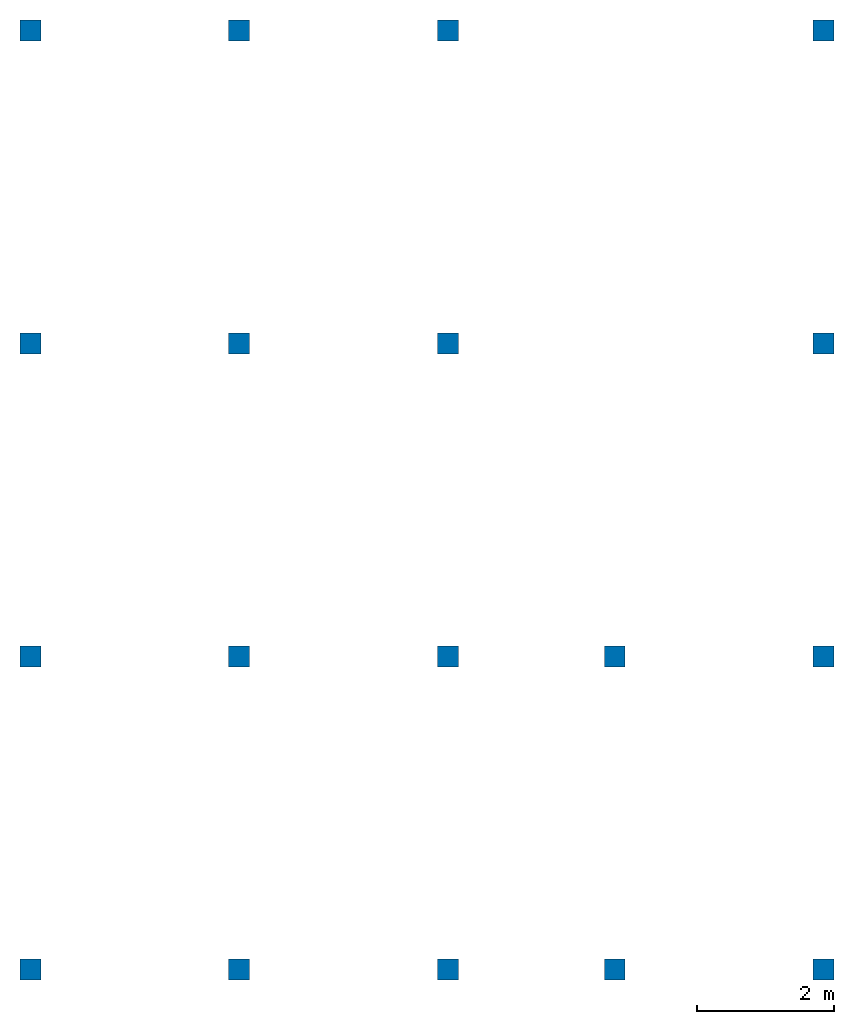
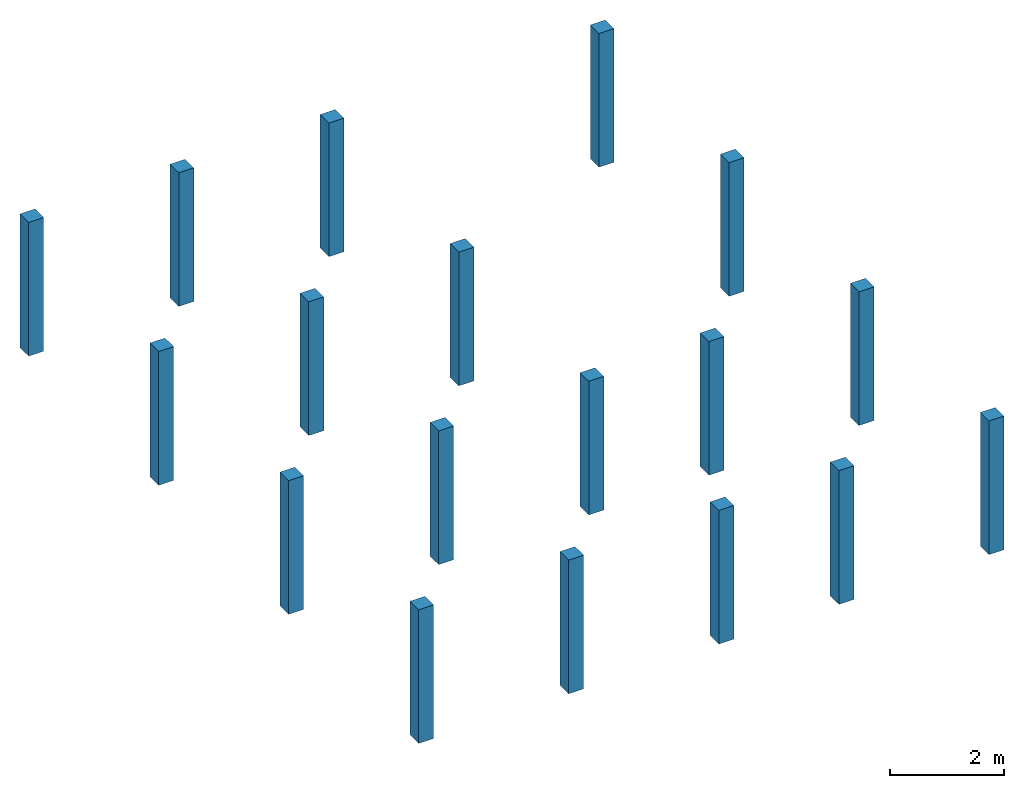
# One storey: 18 columns.
"""IFC2X3 building model written with IfcOpenShell, lengths in feet."""

from ifc_helpers import new_model, entity, si_unit, converted_unit, derived_unit, direction, frame, origin, origin_2d_with_axis, place, context, subcontext, project, spatial, rectangle, extrude, source, transform, mapped, material, type_object, type_shapes, element, save


model = new_model("IFC2X3")

# Units and contexts
model_context = context("Model", 3, precision=0.0001, world=origin(), true_north=direction((6.123031769111886e-17, 1.0)))
body_context = subcontext(model_context, "Body", "Model", "MODEL_VIEW")
ifc_project = project(units=[converted_unit("LENGTHUNIT", "FOOT", entity("IfcLengthMeasure", 0.3048), si_unit("LENGTHUNIT", "METRE"), dimensions=[1, 0, 0, 0, 0, 0, 0]), converted_unit("AREAUNIT", "SQUARE FOOT", entity("IfcAreaMeasure", 0.09290304), si_unit("AREAUNIT", "SQUARE_METRE"), dimensions=[2, 0, 0, 0, 0, 0, 0]), converted_unit("VOLUMEUNIT", "CUBIC FOOT", entity("IfcVolumeMeasure", 0.028316846592000004), si_unit("VOLUMEUNIT", "CUBIC_METRE"), dimensions=[3, 0, 0, 0, 0, 0, 0]), converted_unit("PLANEANGLEUNIT", "DEGREE", entity("IfcPlaneAngleMeasure", 0.017453292519943278), si_unit("PLANEANGLEUNIT", "RADIAN"), dimensions=[0, 0, 0, 0, 0, 0, 0]), si_unit("MASSUNIT", "GRAM", prefix="KILO"), derived_unit("MASSDENSITYUNIT", [(si_unit("MASSUNIT", "GRAM", prefix="KILO"), 1), (si_unit("LENGTHUNIT", "METRE"), -3)]), derived_unit("IONCONCENTRATIONUNIT", [(si_unit("MASSUNIT", "GRAM", prefix="KILO"), 1), (si_unit("LENGTHUNIT", "METRE"), -3)]), derived_unit("MOMENTOFINERTIAUNIT", [(si_unit("LENGTHUNIT", "METRE"), 4)]), si_unit("TIMEUNIT", "SECOND"), si_unit("FREQUENCYUNIT", "HERTZ"), si_unit("THERMODYNAMICTEMPERATUREUNIT", "DEGREE_CELSIUS"), derived_unit("THERMALTRANSMITTANCEUNIT", [(si_unit("MASSUNIT", "GRAM", prefix="KILO"), 1), (si_unit("THERMODYNAMICTEMPERATUREUNIT", "KELVIN"), -1), (si_unit("TIMEUNIT", "SECOND"), -3)]), derived_unit("THERMALCONDUCTANCEUNIT", [(si_unit("MASSUNIT", "GRAM", prefix="KILO"), 1), (si_unit("THERMODYNAMICTEMPERATUREUNIT", "KELVIN"), -1), (si_unit("TIMEUNIT", "SECOND"), -3), (si_unit("LENGTHUNIT", "METRE"), 1)]), derived_unit("VOLUMETRICFLOWRATEUNIT", [(si_unit("LENGTHUNIT", "METRE"), 3), (si_unit("TIMEUNIT", "SECOND"), -1)]), derived_unit("MASSFLOWRATEUNIT", [(si_unit("MASSUNIT", "GRAM", prefix="KILO"), 1), (si_unit("TIMEUNIT", "SECOND"), -1)]), derived_unit("ROTATIONALFREQUENCYUNIT", [(si_unit("TIMEUNIT", "SECOND"), -1)]), si_unit("ELECTRICCURRENTUNIT", "AMPERE"), si_unit("ELECTRICVOLTAGEUNIT", "VOLT"), si_unit("POWERUNIT", "WATT"), converted_unit("FORCEUNIT", "KIP", entity("IfcForceMeasure", 2.088543423315013e-05), si_unit("FORCEUNIT", "NEWTON"), dimensions=[1, 1, -2, 0, 0, 0, 0]), si_unit("ILLUMINANCEUNIT", "LUX"), si_unit("LUMINOUSFLUXUNIT", "LUMEN"), si_unit("LUMINOUSINTENSITYUNIT", "CANDELA"), si_unit("ENERGYUNIT", "JOULE"), derived_unit("USERDEFINED", [(si_unit("MASSUNIT", "GRAM", prefix="KILO"), -1), (si_unit("LENGTHUNIT", "METRE"), -2), (si_unit("TIMEUNIT", "SECOND"), 3), (si_unit("LUMINOUSFLUXUNIT", "LUMEN"), 1)]), derived_unit("USERDEFINED", [(si_unit("MASSUNIT", "GRAM", prefix="KILO"), 1), (si_unit("TIMEUNIT", "SECOND"), -3), (si_unit("LENGTHUNIT", "METRE"), 3), (si_unit("ELECTRICCURRENTUNIT", "AMPERE"), -2)]), derived_unit("SOUNDPOWERUNIT", [(si_unit("MASSUNIT", "GRAM", prefix="KILO"), 1), (si_unit("TIMEUNIT", "SECOND"), -3), (si_unit("LENGTHUNIT", "METRE"), 2)]), derived_unit("SOUNDPRESSUREUNIT", [(si_unit("MASSUNIT", "GRAM", prefix="KILO"), 1), (si_unit("LENGTHUNIT", "METRE"), -1), (si_unit("TIMEUNIT", "SECOND"), -2)]), derived_unit("LINEARVELOCITYUNIT", [(si_unit("LENGTHUNIT", "METRE"), 1), (si_unit("TIMEUNIT", "SECOND"), -1)]), si_unit("PRESSUREUNIT", "PASCAL"), derived_unit("USERDEFINED", [(si_unit("MASSUNIT", "GRAM", prefix="KILO"), 1), (si_unit("LENGTHUNIT", "METRE"), -2), (si_unit("TIMEUNIT", "SECOND"), -2)]), derived_unit("LINEARFORCEUNIT", [(si_unit("MASSUNIT", "GRAM", prefix="KILO"), 1), (si_unit("TIMEUNIT", "SECOND"), -2)]), derived_unit("PLANARFORCEUNIT", [(si_unit("MASSUNIT", "GRAM", prefix="KILO"), 1), (si_unit("LENGTHUNIT", "METRE"), -1), (si_unit("TIMEUNIT", "SECOND"), -2)]), derived_unit("SPECIFICHEATCAPACITYUNIT", [(si_unit("THERMODYNAMICTEMPERATUREUNIT", "KELVIN"), -1), (si_unit("LENGTHUNIT", "METRE"), 2), (si_unit("TIMEUNIT", "SECOND"), -2)]), derived_unit("HEATFLUXDENSITYUNIT", [(si_unit("MASSUNIT", "GRAM", prefix="KILO"), 1), (si_unit("TIMEUNIT", "SECOND"), -3)]), derived_unit("HEATINGVALUEUNIT", [(si_unit("LENGTHUNIT", "METRE"), 2), (si_unit("TIMEUNIT", "SECOND"), -2)]), derived_unit("VAPORPERMEABILITYUNIT", [(si_unit("LENGTHUNIT", "METRE"), -1), (si_unit("TIMEUNIT", "SECOND"), 1)]), derived_unit("DYNAMICVISCOSITYUNIT", [(si_unit("MASSUNIT", "GRAM", prefix="KILO"), 1), (si_unit("TIMEUNIT", "SECOND"), -1), (si_unit("LENGTHUNIT", "METRE"), -1)]), derived_unit("THERMALEXPANSIONCOEFFICIENTUNIT", [(si_unit("THERMODYNAMICTEMPERATUREUNIT", "KELVIN"), -1)]), derived_unit("MODULUSOFELASTICITYUNIT", [(si_unit("MASSUNIT", "GRAM", prefix="KILO"), 1), (si_unit("LENGTHUNIT", "METRE"), -1), (si_unit("TIMEUNIT", "SECOND"), -2)]), derived_unit("ISOTHERMALMOISTURECAPACITYUNIT", [(si_unit("LENGTHUNIT", "METRE"), 3), (si_unit("MASSUNIT", "GRAM", prefix="KILO"), -1)]), derived_unit("MOISTUREDIFFUSIVITYUNIT", [(si_unit("TIMEUNIT", "SECOND"), -1), (si_unit("LENGTHUNIT", "METRE"), 2)]), derived_unit("MASSPERLENGTHUNIT", [(si_unit("MASSUNIT", "GRAM", prefix="KILO"), 1), (si_unit("LENGTHUNIT", "METRE"), -1)]), derived_unit("THERMALRESISTANCEUNIT", [(si_unit("MASSUNIT", "GRAM", prefix="KILO"), -1), (si_unit("TIMEUNIT", "SECOND"), 3), (si_unit("THERMODYNAMICTEMPERATUREUNIT", "KELVIN"), 1)]), derived_unit("ACCELERATIONUNIT", [(si_unit("LENGTHUNIT", "METRE"), 1), (si_unit("TIMEUNIT", "SECOND"), -2)]), derived_unit("ANGULARVELOCITYUNIT", [(si_unit("TIMEUNIT", "SECOND"), -1), (si_unit("PLANEANGLEUNIT", "RADIAN"), 1)]), derived_unit("LINEARSTIFFNESSUNIT", [(si_unit("MASSUNIT", "GRAM", prefix="KILO"), 1), (si_unit("TIMEUNIT", "SECOND"), -2)]), derived_unit("WARPINGCONSTANTUNIT", [(si_unit("LENGTHUNIT", "METRE"), 6)]), derived_unit("LINEARMOMENTUNIT", [(si_unit("MASSUNIT", "GRAM", prefix="KILO"), 1), (si_unit("LENGTHUNIT", "METRE"), 1), (si_unit("TIMEUNIT", "SECOND"), -2)]), derived_unit("TORQUEUNIT", [(si_unit("MASSUNIT", "GRAM", prefix="KILO"), 1), (si_unit("LENGTHUNIT", "METRE"), 2), (si_unit("TIMEUNIT", "SECOND"), -2)])], contexts=[model_context])

# Site, building, storey
site_placement = place(None, origin())
site = spatial("IfcSite", under=ifc_project, at=site_placement, CompositionType="ELEMENT")
building_placement = place(site_placement, origin())
building = spatial("IfcBuilding", under=site, at=building_placement, CompositionType="ELEMENT")
storey_placement = place(building_placement, origin())
storey = spatial("IfcBuildingStorey", under=building, at=storey_placement, Name="Ground Floor", CompositionType="ELEMENT", Elevation=0.0)

# Columns
ifc_material = material(Name="Concrete, Cast-in-Place gray")
column_type = type_object("IfcColumnType", PredefinedType="COLUMN", material=ifc_material)
shared_shape = source(origin(), body_context, "Body", "SweptSolid", [
    extrude(rectangle(XDim=0.9999999999999999, YDim=0.9999999999999999, at=origin_2d_with_axis()), frame((0.0, 0.0, 0.0), z_axis=(0.0, 0.0, 1.0), x_axis=(-1.0, 0.0, 0.0)), (0.0, 0.0, 1.0), 9.416666666670961),
])
type_shapes(column_type, [shared_shape])
for number, where in (
    (1, (9.874478019162162, -49.84124484724893, 0.0)),
    (2, (29.874478019162154, -49.841244847248994, 0.0)),
    (3, (37.87447801916216, -49.84124484724902, 0.0)),
    (4, (47.87447801916217, -49.84124484724906, 0.0)),
    (5, (19.874478019162158, -49.841244847248966, 0.0)),
    (6, (9.874478019162186, -34.84124484724893, 0.0)),
    (7, (29.87447801916219, -34.841244847248994, 0.0)),
    (8, (37.87447801916219, -34.84124484724902, 0.0)),
    (9, (47.87447801916219, -34.84124484724906, 0.0)),
    (10, (19.874478019162183, -34.841244847248966, 0.0)),
    (11, (9.874478019162211, -19.841244847248934, 0.0)),
    (12, (29.87447801916221, -19.841244847248998, 0.0)),
    (13, (47.87447801916221, -19.841244847249058, 0.0)),
    (14, (19.874478019162204, -19.841244847248966, 0.0)),
    (15, (9.874478019162234, -4.841244847248884, 0.0)),
    (16, (29.874478019162233, -4.841244847248948, 0.0)),
    (17, (47.87447801916224, -4.841244847249006, 0.0)),
    (18, (19.87447801916223, -4.841244847248915, 0.0)),
):
    element("IfcColumn", number, at=place(storey_placement, frame(where)), inside=storey, type_object=column_type, material=ifc_material, context=body_context, shape_type="MappedRepresentation", body=[
        mapped(shared_shape, transform((0.0, 0.0, 0.0), scale=1.0)),
    ])

save(model, "model.ifc")
